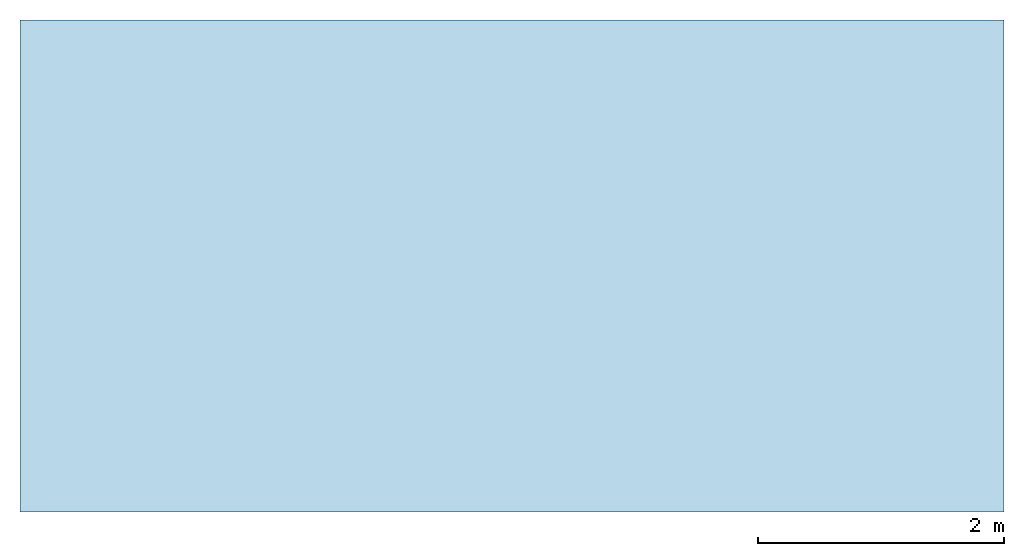
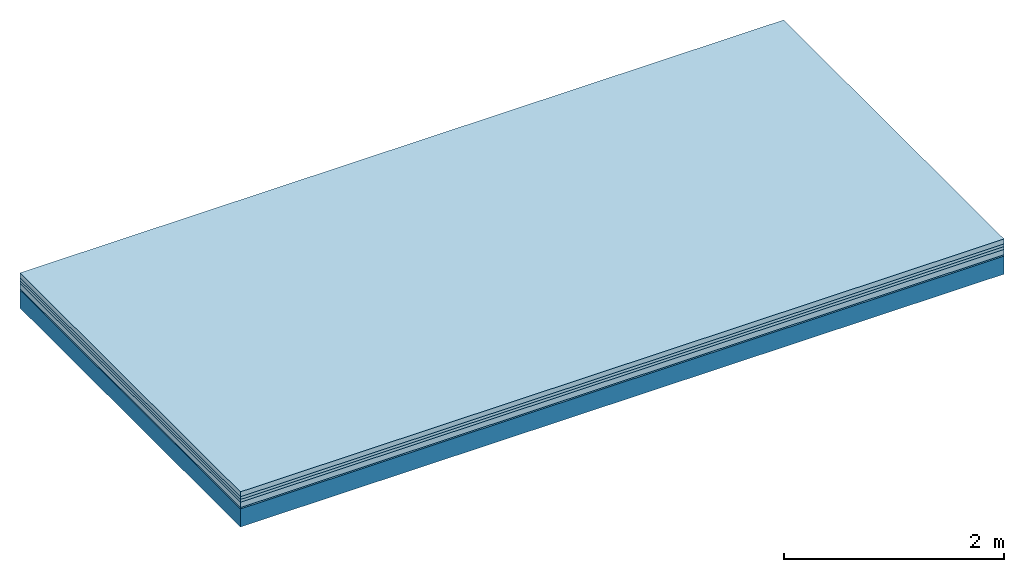
# One storey: 5 plates, 1 member, 1 element without a shape of its own.
"""IFC4 building model written with IfcOpenShell, lengths in metres."""

from ifc_helpers import new_model, si_unit, derived_unit, direction, frame, frame_2d, origin, origin_with_axes, place, context, project, spatial, rectangle, extrude, material, layer, layer_set, type_object, element, aggregate, save


model = new_model("IFC4")

# Units and contexts
plan_context = context("Plan", 3, precision=1e-05, world=origin(), true_north=direction((0.0, 1.0)))
model_context = context("Model", 3, precision=1e-05, world=origin(), true_north=direction((0.0, 1.0)))
ifc_project = project(units=[si_unit("LENGTHUNIT", "METRE"), derived_unit("SOUNDPRESSUREUNIT", [(si_unit("PRESSUREUNIT", "PASCAL", prefix="MICRO"), 0)]), si_unit("ENERGYUNIT", "JOULE", prefix="MEGA"), si_unit("MASSUNIT", "GRAM", prefix="KILO"), derived_unit("THERMALTRANSMITTANCEUNIT", [(si_unit("POWERUNIT", "WATT"), 1), (si_unit("AREAUNIT", "SQUARE_METRE"), -1), (si_unit("THERMODYNAMICTEMPERATUREUNIT", "KELVIN"), -1)]), derived_unit("AREADENSITYUNIT", [(si_unit("MASSUNIT", "GRAM", prefix="KILO"), 1), (si_unit("AREAUNIT", "SQUARE_METRE"), -1)]), derived_unit("USERDEFINED", [(si_unit("ENERGYUNIT", "JOULE", prefix="MEGA"), 1), (si_unit("AREAUNIT", "SQUARE_METRE"), -1)])], contexts=[plan_context, model_context])

# Site, building, storey
site = spatial("IfcSite", under=ifc_project)
building_placement = place(None, origin())
building = spatial("IfcBuilding", under=site, at=building_placement)
storey_placement = place(building_placement, origin())
storey = spatial("IfcBuildingStorey", under=building, at=storey_placement)

# Slab, member, plates
ifc_material_1 = material(Category="04.005")
ifc_layer_1 = layer(ifc_material_1, 0.055, Name="On-material")
ifc_material_2 = material()
ifc_layer_2 = layer(ifc_material_2, 0.03, Name="Impact sound insulation")
ifc_material_3 = material()
ifc_layer_3 = layer(ifc_material_3, 0.03, Name="Additional insulation")
ifc_material_4 = material(Category="03.011")
ifc_layer_4 = layer(ifc_material_4, 0.06, Name="on Supporting structure")
ifc_material_5 = material(Category="03.007")
ifc_layer_5 = layer(ifc_material_5, 0.015, Name="Sub-floor")
ifc_material_6 = material(Name="of the art")
ifc_layer_6 = layer(ifc_material_6, 0.0, Name="Bond")
ifc_layer_7 = layer(None, 0.2, Name="Supporting structure")
ifc_layer_set = layer_set([ifc_layer_1, ifc_layer_2, ifc_layer_3, ifc_layer_4, ifc_layer_5, ifc_layer_6, ifc_layer_7])
slab_type = type_object("IfcSlabType", Name="A1094", PredefinedType="NOTDEFINED", material=ifc_layer_set)
slab_placement = place(None, frame((0.0, 0.0, 0.0), z_axis=(0.0, 0.0, -1.0), x_axis=(1.0, 0.0, 0.0)))
slab = element("IfcSlab", 1, at=slab_placement, inside=storey, type_object=slab_type, material=ifc_layer_set, Name="Slab #1")
ifc_material_7 = material()
member_placement = place(slab_placement, origin())
member = element("IfcMember", 2, at=member_placement, material=ifc_material_7, Name="Supporting structure", context=plan_context, shape_type="SweptSolid", body=[
    extrude(rectangle(XDim=1.0, YDim=0.2, at=frame_2d((0.5, 0.1), x_axis=(1.0, 0.0))), frame((0.0, 4.0, 0.19), z_axis=(0.0, -1.0, 0.0), x_axis=(1.0, 0.0, 0.0)), (0.0, 0.0, 1.0), 4.0),
    extrude(rectangle(XDim=1.0, YDim=0.2, at=frame_2d((0.5, 0.1), x_axis=(1.0, 0.0))), frame((1.0, 4.0, 0.19), z_axis=(0.0, -1.0, 0.0), x_axis=(1.0, 0.0, 0.0)), (0.0, 0.0, 1.0), 4.0),
    extrude(rectangle(XDim=1.0, YDim=0.2, at=frame_2d((0.5, 0.1), x_axis=(1.0, 0.0))), frame((2.0, 4.0, 0.19), z_axis=(0.0, -1.0, 0.0), x_axis=(1.0, 0.0, 0.0)), (0.0, 0.0, 1.0), 4.0),
    extrude(rectangle(XDim=1.0, YDim=0.2, at=frame_2d((0.5, 0.1), x_axis=(1.0, 0.0))), frame((3.0, 4.0, 0.19), z_axis=(0.0, -1.0, 0.0), x_axis=(1.0, 0.0, 0.0)), (0.0, 0.0, 1.0), 4.0),
    extrude(rectangle(XDim=1.0, YDim=0.2, at=frame_2d((0.5, 0.1), x_axis=(1.0, 0.0))), frame((4.0, 4.0, 0.19), z_axis=(0.0, -1.0, 0.0), x_axis=(1.0, 0.0, 0.0)), (0.0, 0.0, 1.0), 4.0),
    extrude(rectangle(XDim=1.0, YDim=0.2, at=frame_2d((0.5, 0.1), x_axis=(1.0, 0.0))), frame((5.0, 4.0, 0.19), z_axis=(0.0, -1.0, 0.0), x_axis=(1.0, 0.0, 0.0)), (0.0, 0.0, 1.0), 4.0),
    extrude(rectangle(XDim=1.0, YDim=0.2, at=frame_2d((0.5, 0.1), x_axis=(1.0, 0.0))), frame((6.0, 4.0, 0.19), z_axis=(0.0, -1.0, 0.0), x_axis=(1.0, 0.0, 0.0)), (0.0, 0.0, 1.0), 4.0),
    extrude(rectangle(XDim=1.0, YDim=0.2, at=frame_2d((0.5, 0.1), x_axis=(1.0, 0.0))), frame((7.0, 4.0, 0.19), z_axis=(0.0, -1.0, 0.0), x_axis=(1.0, 0.0, 0.0)), (0.0, 0.0, 1.0), 4.0),
])
plate_1_placement = place(slab_placement, origin())
plate_1 = element("IfcPlate", 3, at=plate_1_placement, material=ifc_material_1, Name="On-material", context=plan_context, shape_type="SweptSolid", body=[
    extrude(rectangle(XDim=8.0, YDim=4.0, at=frame_2d((4.0, 2.0), x_axis=(1.0, 0.0))), origin_with_axes(), (0.0, 0.0, 1.0), 0.055),
])
plate_2_placement = place(slab_placement, origin())
plate_2 = element("IfcPlate", 4, at=plate_2_placement, material=ifc_material_2, Name="Impact sound insulation", context=plan_context, shape_type="SweptSolid", body=[
    extrude(rectangle(XDim=8.0, YDim=4.0, at=frame_2d((4.0, 2.0), x_axis=(1.0, 0.0))), frame((0.0, 0.0, 0.055), z_axis=(0.0, 0.0, 1.0), x_axis=(1.0, 0.0, 0.0)), (0.0, 0.0, 1.0), 0.03),
])
plate_3_placement = place(slab_placement, origin())
plate_3 = element("IfcPlate", 5, at=plate_3_placement, material=ifc_material_3, Name="Additional insulation", context=plan_context, shape_type="SweptSolid", body=[
    extrude(rectangle(XDim=8.0, YDim=4.0, at=frame_2d((4.0, 2.0), x_axis=(1.0, 0.0))), frame((0.0, 0.0, 0.085), z_axis=(0.0, 0.0, 1.0), x_axis=(1.0, 0.0, 0.0)), (0.0, 0.0, 1.0), 0.03),
])
plate_4_placement = place(slab_placement, origin())
plate_4 = element("IfcPlate", 6, at=plate_4_placement, material=ifc_material_4, Name="on Supporting structure", context=plan_context, shape_type="SweptSolid", body=[
    extrude(rectangle(XDim=8.0, YDim=4.0, at=frame_2d((4.0, 2.0), x_axis=(1.0, 0.0))), frame((0.0, 0.0, 0.115), z_axis=(0.0, 0.0, 1.0), x_axis=(1.0, 0.0, 0.0)), (0.0, 0.0, 1.0), 0.06),
])
plate_5_placement = place(slab_placement, origin())
plate_5 = element("IfcPlate", 7, at=plate_5_placement, material=ifc_material_5, Name="Sub-floor", context=plan_context, shape_type="SweptSolid", body=[
    extrude(rectangle(XDim=8.0, YDim=4.0, at=frame_2d((4.0, 2.0), x_axis=(1.0, 0.0))), frame((0.0, 0.0, 0.175), z_axis=(0.0, 0.0, 1.0), x_axis=(1.0, 0.0, 0.0)), (0.0, 0.0, 1.0), 0.015),
])
aggregate(slab, [plate_1, plate_2, plate_3, plate_4, plate_5, member])

save(model, "model.ifc")
